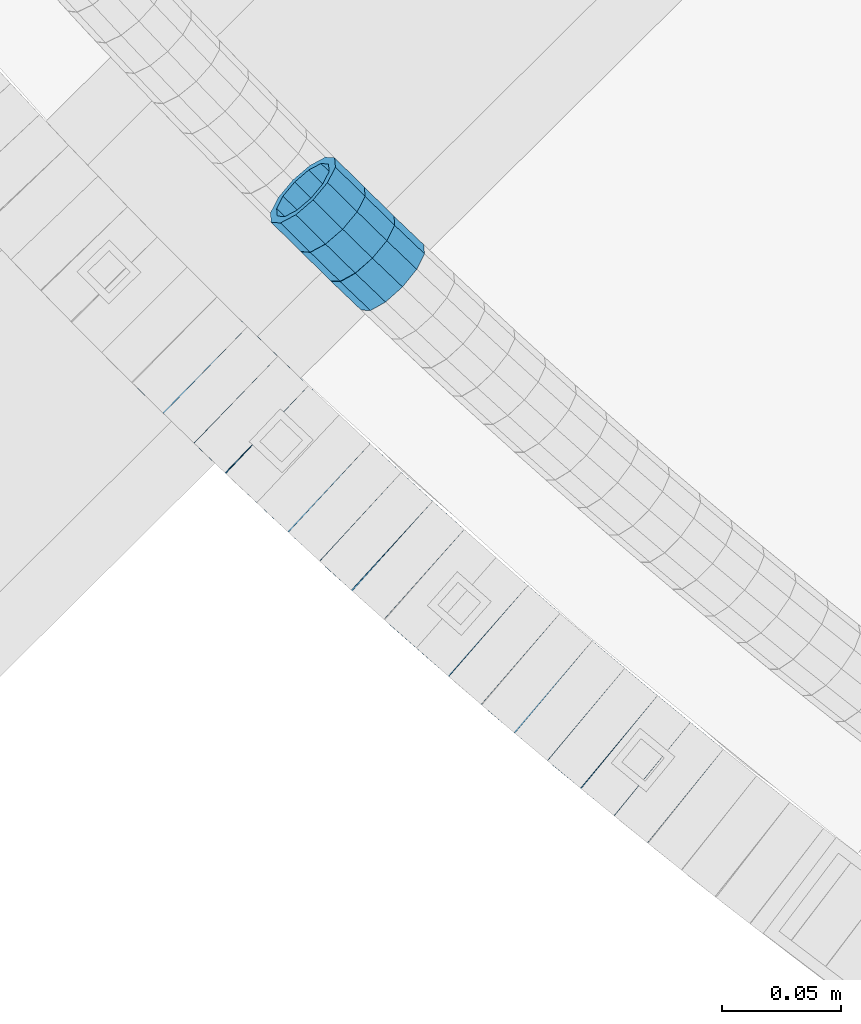
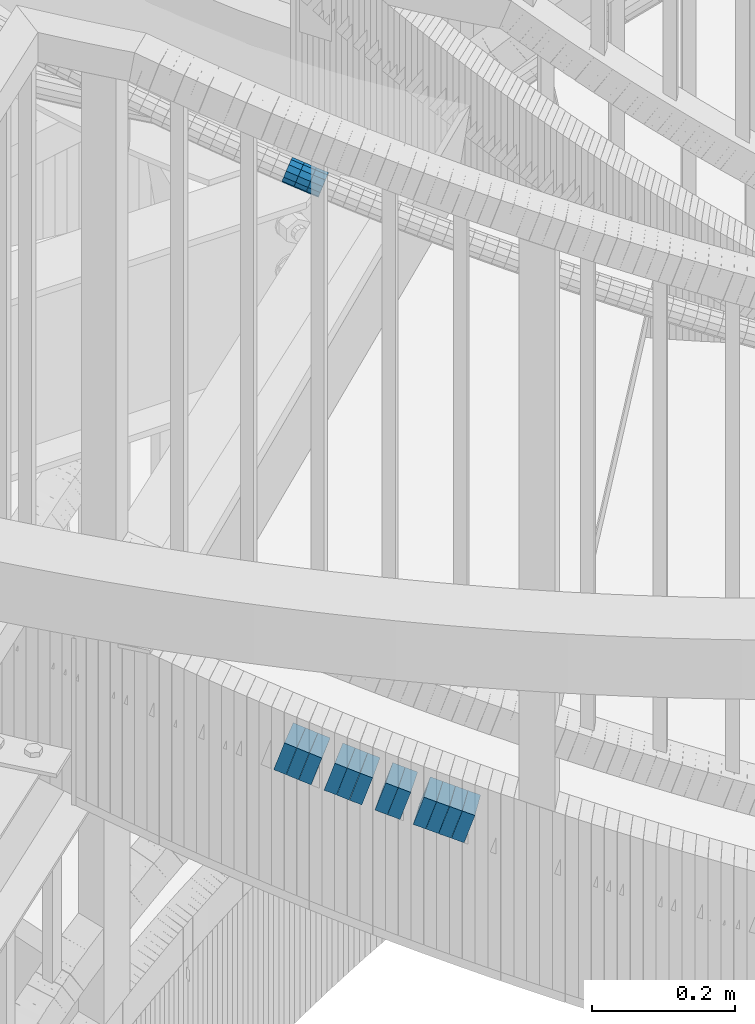
# One storey, part 662 of 975: 15 beams.
"""IFC2X3 building model written with IfcOpenShell, lengths in millimetres."""

from ifc_helpers import new_model, si_unit, frame, origin_with_axes, place, context, subcontext, project, spatial, faceted_brep, material, type_object, element, save


model = new_model("IFC2X3")

# Units and contexts
model_context = context("Model", 3, precision=1e-05, world=origin_with_axes())
body_context = subcontext(model_context, "Body", "Model", "MODEL_VIEW")
ifc_project = project(units=[si_unit("LENGTHUNIT", "METRE", prefix="MILLI"), si_unit("AREAUNIT", "SQUARE_METRE"), si_unit("VOLUMEUNIT", "CUBIC_METRE"), si_unit("MASSUNIT", "GRAM", prefix="KILO"), si_unit("TIMEUNIT", "SECOND"), si_unit("PLANEANGLEUNIT", "RADIAN"), si_unit("SOLIDANGLEUNIT", "STERADIAN"), si_unit("THERMODYNAMICTEMPERATUREUNIT", "DEGREE_CELSIUS"), si_unit("LUMINOUSINTENSITYUNIT", "LUMEN")], contexts=[model_context])

# Site, building, storey
site_placement = place(None, origin_with_axes())
site = spatial("IfcSite", under=ifc_project, at=site_placement, CompositionType="ELEMENT")
building_placement = place(site_placement, origin_with_axes())
building = spatial("IfcBuilding", under=site, at=building_placement, Name="Undefined", CompositionType="ELEMENT")
storey_placement = place(building_placement, origin_with_axes())
storey = spatial("IfcBuildingStorey", under=building, at=storey_placement, Name="Undefined", CompositionType="ELEMENT", Elevation=0.0)

# Beams
ifc_material = material()
beam_type_1 = type_object("IfcBeamType", PredefinedType="NOTDEFINED")
beam_1_placement = place(storey_placement, frame((32770.5328769577, 1424.90290854378, 4922.613522137), z_axis=(0.701381499778907, 0.712786077142287, 8.51287040859459e-11), x_axis=(0.676734364812168, -0.665906614815096, -0.314004744912829)))
element("IfcBeam", 1, at=beam_1_placement, inside=storey, type_object=beam_type_1, material=ifc_material, Name="WALL", context=body_context, shape_type="Brep", body=[
    faceted_brep([(-2.1246523829177e-07, -15.367000000002, 0.0), (-1.83998054126278e-07, -13.3082123799541, 7.68350000000009), (18.4672683416502, -13.3082123799759, 7.68350000002465), (18.4672683416611, -15.3670000000202, 3.09228198602796e-11), (-1.06232619145885e-07, -7.68349999999919, 13.3082123799559), (18.467268341632, -7.68350000001737, 13.3082123799704), (-3.63797880709171e-12, 3.63797880709171e-12, 15.3670000000002), (18.4672683416175, -1.09139364212751e-11, 15.3670000000075), (1.06225343188271e-07, 7.68350000000646, 13.3082123799559), (18.4672683416102, 7.68349999998827, 13.3082123799613), (1.8399441614747e-07, 13.308212379965, 7.68350000000009), (18.4672683416138, 13.3082123799468, 7.68350000000464), (2.12461600312963e-07, 15.3670000000093, 0.0), (18.4672683416138, 15.3669999999929, 5.45696821063757e-12), (1.8399441614747e-07, 13.308212379965, -7.68350000000009), (18.4672683416284, 13.308212379945, -7.68349999998827), (1.06225343188271e-07, 7.68350000000646, -13.3082123799559), (18.4672683416429, 7.68349999998827, -13.3082123799359), (-3.63797880709171e-12, 3.63797880709171e-12, -15.3670000000002), (18.4672683416611, -1.63709046319127e-11, -15.3669999999747), (-1.06232619145885e-07, -7.68349999999919, -13.3082123799559), (18.4672683416647, -7.68350000001919, -13.3082123799268), (-1.83998054126278e-07, -13.3082123799541, -7.68350000000009), (18.4672683416684, -13.3082123799759, -7.68349999997008), (-2.63386027654633e-07, -19.0500000000029, 0.0), (-2.28097633225843e-07, -16.4977839420972, -9.52499999999964), (18.4672683416793, -16.4977839421172, -9.52499999996508), (18.467268341672, -19.0500000000247, 3.27418092638254e-11), (-1.31691194837913e-07, -9.52500000000146, -16.4977839420935), (18.4672683416757, -9.52500000002328, -16.497783942059), (-3.63797880709171e-12, 3.63797880709171e-12, -19.0500000000002), (18.4672683416611, -1.45519152283669e-11, -19.0499999999738), (1.31687556859106e-07, 9.52500000000509, -16.4977839420935), (18.4672683416502, 9.5249999999869, -16.4977839420735), (2.28097633225843e-07, 16.4977839421044, -9.52499999999964), (18.4672683416247, 16.4977839420862, -9.52499999998872), (2.63382389675826e-07, 19.0500000000138, 0.0), (18.4672683416029, 19.0499999999956, 1.81898940354586e-12), (2.28097633225843e-07, 16.4977839421044, 9.52499999999964), (18.4672683416065, 16.4977839420862, 9.52500000000146), (1.31687556859106e-07, 9.52500000000509, 16.4977839420935), (18.4672683415993, 9.52499999999236, 16.4977839420917), (-3.63797880709171e-12, 3.63797880709171e-12, 19.0500000000002), (18.4672683416138, -1.45519152283669e-11, 19.0500000000084), (-1.31691194837913e-07, -9.52500000000146, 16.4977839420935), (18.4672683416356, -9.52500000001783, 16.4977839421117), (-2.28097633225843e-07, -16.4977839420972, 9.52499999999964), (18.4672683416538, -16.4977839421135, 9.5250000000251)], [[[0, 1, 2, 3]], [[1, 4, 5, 2]], [[4, 6, 7, 5]], [[6, 8, 9, 7]], [[8, 10, 11, 9]], [[10, 12, 13, 11]], [[12, 14, 15, 13]], [[14, 16, 17, 15]], [[16, 18, 19, 17]], [[18, 20, 21, 19]], [[20, 22, 23, 21]], [[22, 0, 3, 23]], [[24, 25, 26, 27]], [[25, 28, 29, 26]], [[28, 30, 31, 29]], [[30, 32, 33, 31]], [[32, 34, 35, 33]], [[34, 36, 37, 35]], [[36, 38, 39, 37]], [[38, 40, 41, 39]], [[40, 42, 43, 41]], [[42, 44, 45, 43]], [[44, 46, 47, 45]], [[46, 24, 27, 47]], [[29, 31, 33, 35, 37, 39, 41, 43, 45, 47, 27, 26], [5, 7, 9, 11, 13, 15, 17, 19, 21, 23, 3, 2]], [[46, 44, 42, 40, 38, 36, 34, 32, 30, 28, 25, 24], [22, 20, 18, 16, 14, 12, 10, 8, 6, 4, 1, 0]]]),
])
beam_2_placement = place(storey_placement, frame((32795.5342645722, 1400.26836988703, 4911.08251313694), z_axis=(0.689797510046803, 0.724002344701473, -7.79255060479045e-11), x_axis=(0.688561837943278, -0.656031357946014, -0.309039564974591)))
element("IfcBeam", 2, at=beam_2_placement, inside=storey, type_object=beam_type_1, material=ifc_material, Name="WALL", context=body_context, shape_type="Brep", body=[
    faceted_brep([(-2.1246523829177e-07, -15.367000000002, 0.0), (-1.83998054126278e-07, -13.3082123799541, 7.68350000000009), (18.4442402933746, -13.3082123799431, 7.68349999998463), (18.4442402933928, -15.3669999999893, -3.63797880709171e-12), (-1.06232619145885e-07, -7.68349999999919, 13.3082123799559), (18.4442402933564, -7.68349999998281, 13.308212379925), (-3.63797880709171e-12, 3.63797880709171e-12, 15.3670000000002), (18.4442402933455, 1.81898940354586e-11, 15.3669999999584), (1.06225343188271e-07, 7.68350000000646, 13.3082123799559), (18.4442402933419, 7.68350000001737, 13.3082123799104), (1.8399441614747e-07, 13.308212379965, 7.68350000000009), (18.4442402933528, 13.3082123799722, 7.68349999996281), (2.12461600312963e-07, 15.3670000000093, 0.0), (18.4442402933637, 15.3670000000129, -2.5465851649642e-11), (1.8399441614747e-07, 13.308212379965, -7.68350000000009), (18.4442402933855, 13.308212379965, -7.6835000000101), (1.06225343188271e-07, 7.68350000000646, -13.3082123799559), (18.4442402934037, 7.68350000000646, -13.3082123799541), (-3.63797880709171e-12, 3.63797880709171e-12, -15.3670000000002), (18.444240293411, 5.45696821063757e-12, -15.3669999999911), (-1.06232619145885e-07, -7.68349999999919, -13.3082123799559), (18.4442402934146, -7.68349999999373, -13.3082123799431), (-1.83998054126278e-07, -13.3082123799541, -7.68350000000009), (18.4442402934037, -13.3082123799468, -7.68349999999191), (-2.63386027654633e-07, -19.0500000000029, 0.0), (-2.28097633225843e-07, -16.4977839420972, -9.52499999999964), (18.444240293411, -16.4977839420862, -9.5249999999869), (18.4442402933964, -19.0499999999902, 0.0), (-1.31691194837913e-07, -9.52500000000146, -16.4977839420935), (18.4442402934219, -9.524999999996, -16.4977839420717), (-3.63797880709171e-12, 3.63797880709171e-12, -19.0500000000002), (18.4442402934183, 3.63797880709171e-12, -19.0499999999847), (1.31687556859106e-07, 9.52500000000509, -16.4977839420935), (18.4442402934073, 9.52500000000509, -16.4977839420899), (2.28097633225843e-07, 16.4977839421044, -9.52499999999964), (18.4442402933855, 16.4977839421008, -9.52500000001601), (2.63382389675826e-07, 19.0500000000138, 0.0), (18.4442402933637, 19.0500000000138, -2.91038304567337e-11), (2.28097633225843e-07, 16.4977839421044, 9.52499999999964), (18.4442402933419, 16.4977839421117, 9.52499999995052), (1.31687556859106e-07, 9.52500000000509, 16.4977839420935), (18.4442402933346, 9.52500000001965, 16.4977839420426), (-3.63797880709171e-12, 3.63797880709171e-12, 19.0500000000002), (18.4442402933346, 2.00088834390044e-11, 19.0499999999483), (-1.31691194837913e-07, -9.52500000000146, 16.4977839420935), (18.4442402933528, -9.52499999998145, 16.4977839420571), (-2.28097633225843e-07, -16.4977839420972, 9.52499999999964), (18.4442402933746, -16.497783942079, 9.52499999998327)], [[[0, 1, 2, 3]], [[1, 4, 5, 2]], [[4, 6, 7, 5]], [[6, 8, 9, 7]], [[8, 10, 11, 9]], [[10, 12, 13, 11]], [[12, 14, 15, 13]], [[14, 16, 17, 15]], [[16, 18, 19, 17]], [[18, 20, 21, 19]], [[20, 22, 23, 21]], [[22, 0, 3, 23]], [[24, 25, 26, 27]], [[25, 28, 29, 26]], [[28, 30, 31, 29]], [[30, 32, 33, 31]], [[32, 34, 35, 33]], [[34, 36, 37, 35]], [[36, 38, 39, 37]], [[38, 40, 41, 39]], [[40, 42, 43, 41]], [[42, 44, 45, 43]], [[44, 46, 47, 45]], [[46, 24, 27, 47]], [[29, 31, 33, 35, 37, 39, 41, 43, 45, 47, 27, 26], [5, 7, 9, 11, 13, 15, 17, 19, 21, 23, 3, 2]], [[46, 44, 42, 40, 38, 36, 34, 32, 30, 28, 25, 24], [22, 20, 18, 16, 14, 12, 10, 8, 6, 4, 1, 0]]]),
])
beam_3_placement = place(storey_placement, frame((32783.0672260718, 1412.53527391315, 4916.78990991588), z_axis=(0.698466923246537, 0.715642338833105, -9.56160874920895e-11), x_axis=(0.680333189806667, -0.664005193811269, -0.310231934911841)))
element("IfcBeam", 3, at=beam_3_placement, inside=storey, type_object=beam_type_1, material=ifc_material, Name="WALL", context=body_context, shape_type="Brep", body=[
    faceted_brep([(-2.1246523829177e-07, -15.367000000002, 0.0), (-1.83998054126278e-07, -13.3082123799541, 7.68350000000009), (18.3709009033701, -13.308212379965, 7.68350000000646), (18.370900903381, -15.3670000000202, 1.09139364212751e-11), (-1.06232619145885e-07, -7.68349999999919, 13.3082123799559), (18.3709009033519, -7.68349999999919, 13.3082123799559), (-3.63797880709171e-12, 3.63797880709171e-12, 15.3670000000002), (18.3709009033337, 1.09139364212751e-11, 15.3669999999893), (1.06225343188271e-07, 7.68350000000646, 13.3082123799559), (18.3709009033155, 7.68350000001737, 13.3082123799395), (1.8399441614747e-07, 13.308212379965, 7.68350000000009), (18.3709009033191, 13.3082123799759, 7.68349999998463), (2.12461600312963e-07, 15.3670000000093, 0.0), (18.3709009033191, 15.3670000000166, -1.45519152283669e-11), (1.8399441614747e-07, 13.308212379965, -7.68350000000009), (18.3709009033337, 13.3082123799613, -7.68350000000828), (1.06225343188271e-07, 7.68350000000646, -13.3082123799559), (18.3709009033482, 7.68349999999555, -13.3082123799577), (-3.63797880709171e-12, 3.63797880709171e-12, -15.3670000000002), (18.3709009033737, -1.45519152283669e-11, -15.3669999999929), (-1.06232619145885e-07, -7.68349999999919, -13.3082123799559), (18.3709009033846, -7.68350000002101, -13.3082123799431), (-1.83998054126278e-07, -13.3082123799541, -7.68350000000009), (18.3709009033846, -13.3082123799759, -7.68349999998827), (-2.63386027654633e-07, -19.0500000000029, 0.0), (-2.28097633225843e-07, -16.4977839420972, -9.52499999999964), (18.3709009033992, -16.4977839421226, -9.52499999998145), (18.3709009033882, -19.0500000000229, 1.45519152283669e-11), (-1.31691194837913e-07, -9.52500000000146, -16.4977839420935), (18.3709009033919, -9.52500000002692, -16.4977839420771), (-3.63797880709171e-12, 3.63797880709171e-12, -19.0500000000002), (18.3709009033701, -1.45519152283669e-11, -19.0499999999938), (1.31687556859106e-07, 9.52500000000509, -16.4977839420935), (18.3709009033519, 9.524999999996, -16.4977839420935), (2.28097633225843e-07, 16.4977839421044, -9.52499999999964), (18.37090090333, 16.4977839421044, -9.52500000001055), (2.63382389675826e-07, 19.0500000000138, 0.0), (18.3709009033118, 19.0500000000211, -1.81898940354586e-11), (2.28097633225843e-07, 16.4977839421044, 9.52499999999964), (18.3709009033082, 16.497783942119, 9.52499999997963), (1.31687556859106e-07, 9.52500000000509, 16.4977839420935), (18.3709009033118, 9.52500000002328, 16.4977839420753), (-3.63797880709171e-12, 3.63797880709171e-12, 19.0500000000002), (18.37090090333, 1.45519152283669e-11, 19.0499999999902), (-1.31691194837913e-07, -9.52500000000146, 16.4977839420935), (18.3709009033555, -9.52499999999782, 16.4977839420935), (-2.28097633225843e-07, -16.4977839420972, 9.52499999999964), (18.370900903381, -16.4977839421081, 9.52500000000873)], [[[0, 1, 2, 3]], [[1, 4, 5, 2]], [[4, 6, 7, 5]], [[6, 8, 9, 7]], [[8, 10, 11, 9]], [[10, 12, 13, 11]], [[12, 14, 15, 13]], [[14, 16, 17, 15]], [[16, 18, 19, 17]], [[18, 20, 21, 19]], [[20, 22, 23, 21]], [[22, 0, 3, 23]], [[24, 25, 26, 27]], [[25, 28, 29, 26]], [[28, 30, 31, 29]], [[30, 32, 33, 31]], [[32, 34, 35, 33]], [[34, 36, 37, 35]], [[36, 38, 39, 37]], [[38, 40, 41, 39]], [[40, 42, 43, 41]], [[42, 44, 45, 43]], [[44, 46, 47, 45]], [[46, 24, 27, 47]], [[29, 31, 33, 35, 37, 39, 41, 43, 45, 47, 27, 26], [5, 7, 9, 11, 13, 15, 17, 19, 21, 23, 3, 2]], [[46, 44, 42, 40, 38, 36, 34, 32, 30, 28, 25, 24], [22, 20, 18, 16, 14, 12, 10, 8, 6, 4, 1, 0]]]),
])
beam_type_2 = type_object("IfcBeamType", Name="HSS2X2X.188_TUBES", PredefinedType="NOTDEFINED")
beam_4_placement = place(storey_placement, frame((32724.0344169392, 1354.4145673792, 3996.30731278571), z_axis=(0.695795215779443, 0.718240222835256, 1.40034899231978e-11), x_axis=(0.684100829257296, -0.662722678249241, -0.304638650114579)))
element("IfcBeam", 4, at=beam_4_placement, inside=storey, type_object=beam_type_2, material=ifc_material, Name="WALL", ObjectType="HSS2X2X.188_TUBES", context=body_context, shape_type="Brep", body=[
    faceted_brep([(0.0, 20.6374999999753, -20.6375000000298), (0.0, -20.6375000000153, -20.6375000000153), (18.7112265765609, -20.6375000000062, -20.6374999999862), (18.7112265765645, 20.6374999999898, -20.6374999999789), (0.0, -20.6374999999825, 20.6375000000335), (18.7112265765209, -20.6374999999916, 20.6374999999607), (0.0, 20.6375000000116, 20.6375000000189), (18.7112265765245, 20.6375000000025, 20.6374999999716), (0.0, 25.3999999999724, -25.4000000000342), (0.0, 25.400000000016, 25.4000000000196), (18.7112265765172, 25.4000000000051, 25.3999999999614), (18.7112265765718, 25.3999999999887, -25.3999999999724), (0.0, -25.399999999976, 25.4000000000378), (18.7112265765136, -25.3999999999905, 25.3999999999542), (0.0, -25.400000000016, -25.4000000000196), (18.7112265765682, -25.4000000000069, -25.3999999999796)], [[[0, 1, 2, 3]], [[1, 4, 5, 2]], [[4, 6, 7, 5]], [[6, 0, 3, 7]], [[8, 9, 10, 11]], [[9, 12, 13, 10]], [[12, 14, 15, 13]], [[14, 8, 11, 15]], [[13, 15, 11, 10], [5, 7, 3, 2]], [[14, 12, 9, 8], [6, 4, 1, 0]]]),
])
beam_5_placement = place(storey_placement, frame((32736.9049610275, 1341.90475522226, 3990.59829667296), z_axis=(0.692997020219925, 0.720940448280095, 1.13263922685292e-11), x_axis=(0.686928616140534, -0.660303476135105, -0.303526598062094)))
element("IfcBeam", 5, at=beam_5_placement, inside=storey, type_object=beam_type_2, material=ifc_material, Name="WALL", ObjectType="HSS2X2X.188_TUBES", context=body_context, shape_type="Brep", body=[
    faceted_brep([(0.0, 20.6374999999753, -20.6375000000298), (0.0, -20.6375000000153, -20.6375000000153), (18.7771137292038, -20.637500000008, -20.6374999999862), (18.777113729182, 20.6375000000062, -20.6375000000189), (0.0, -20.6374999999825, 20.6375000000335), (18.7771137291729, -20.6374999999916, 20.6374999999753), (0.0, 20.6375000000116, 20.6375000000189), (18.7771137291529, 20.6375000000207, 20.6374999999389), (0.0, 25.3999999999724, -25.4000000000342), (0.0, 25.400000000016, 25.4000000000196), (18.7771137291475, 25.4000000000251, 25.3999999999287), (18.7771137291857, 25.4000000000051, -25.4000000000196), (0.0, -25.399999999976, 25.4000000000378), (18.7771137291711, -25.3999999999905, 25.3999999999724), (0.0, -25.400000000016, -25.4000000000196), (18.7771137292129, -25.4000000000124, -25.3999999999724)], [[[0, 1, 2, 3]], [[1, 4, 5, 2]], [[4, 6, 7, 5]], [[6, 0, 3, 7]], [[8, 9, 10, 11]], [[9, 12, 13, 10]], [[12, 14, 15, 13]], [[14, 8, 11, 15]], [[13, 15, 11, 10], [5, 7, 3, 2]], [[14, 12, 9, 8], [6, 4, 1, 0]]]),
])
beam_6_placement = place(storey_placement, frame((32749.8715593652, 1329.35444516325, 3984.91567673949), z_axis=(0.687119514852114, 0.726544404912319, 1.51526364788878e-11), x_axis=(0.691771053474231, -0.65423308944851, -0.305666279209551)))
element("IfcBeam", 6, at=beam_6_placement, inside=storey, type_object=beam_type_2, material=ifc_material, Name="WALL", ObjectType="HSS2X2X.188_TUBES", context=body_context, shape_type="Brep", body=[
    faceted_brep([(0.0, 20.6374999999753, -20.6375000000298), (0.0, -20.6375000000153, -20.6375000000153), (18.6531498680506, -20.6374999999862, -20.6375000000007), (18.6531498680579, 20.637500000008, -20.6374999999935), (0.0, -20.6374999999825, 20.6375000000335), (18.6531498680379, -20.6374999999971, 20.6374999999789), (0.0, 20.6375000000116, 20.6375000000189), (18.6531498680451, 20.6374999999989, 20.6374999999898), (0.0, 25.3999999999724, -25.4000000000342), (0.0, 25.400000000016, 25.4000000000196), (18.653149868047, 25.399999999996, 25.3999999999869), (18.6531498680633, 25.4000000000087, -25.3999999999905), (0.0, -25.399999999976, 25.4000000000378), (18.6531498680361, -25.3999999999978, 25.3999999999796), (0.0, -25.400000000016, -25.4000000000196), (18.6531498680488, -25.3999999999851, -25.4000000000015)], [[[0, 1, 2, 3]], [[1, 4, 5, 2]], [[4, 6, 7, 5]], [[6, 0, 3, 7]], [[8, 9, 10, 11]], [[9, 12, 13, 10]], [[12, 14, 15, 13]], [[14, 8, 11, 15]], [[13, 15, 11, 10], [5, 7, 3, 2]], [[14, 12, 9, 8], [6, 4, 1, 0]]]),
])
beam_7_placement = place(storey_placement, frame((32776.0502930621, 1304.66244969557, 3973.40583006654), z_axis=(0.678512969955015, 0.734588421909048, -9.16134013095869e-12), x_axis=(0.699714846980974, -0.646301499982326, -0.304456078991678)))
element("IfcBeam", 7, at=beam_7_placement, inside=storey, type_object=beam_type_2, material=ifc_material, Name="WALL", ObjectType="HSS2X2X.188_TUBES", context=body_context, shape_type="Brep", body=[
    faceted_brep([(0.0, 20.6374999999753, -20.6375000000298), (0.0, -20.6375000000153, -20.6375000000153), (18.724849799155, -20.6375000000171, -20.6374999999425), (18.7248497991204, 20.6374999999989, -20.6375000000007), (0.0, -20.6374999999825, 20.6375000000335), (18.7248497991168, -20.6374999999953, 20.6375000000007), (0.0, 20.6375000000116, 20.6375000000189), (18.724849799084, 20.6375000000226, 20.6374999999498), (0.0, 25.3999999999724, -25.4000000000342), (0.0, 25.400000000016, 25.4000000000196), (18.7248497990731, 25.4000000000269, 25.399999999936), (18.7248497991204, 25.3999999999978, -25.3999999999978), (0.0, -25.399999999976, 25.4000000000378), (18.7248497991186, -25.3999999999942, 25.4000000000051), (0.0, -25.400000000016, -25.4000000000196), (18.7248497991604, -25.4000000000233, -25.3999999999323)], [[[0, 1, 2, 3]], [[1, 4, 5, 2]], [[4, 6, 7, 5]], [[6, 0, 3, 7]], [[8, 9, 10, 11]], [[9, 12, 13, 10]], [[12, 14, 15, 13]], [[14, 8, 11, 15]], [[13, 15, 11, 10], [5, 7, 3, 2]], [[14, 12, 9, 8], [6, 4, 1, 0]]]),
])
beam_8_placement = place(storey_placement, frame((32789.2225427684, 1292.4562229374, 3967.69662764212), z_axis=(0.675724628076021, 0.737154140605289, 3.47004515788284e-10), x_axis=(0.702425832939866, -0.643890345944859, -0.303320245974027)))
element("IfcBeam", 8, at=beam_8_placement, inside=storey, type_object=beam_type_2, material=ifc_material, Name="WALL", ObjectType="HSS2X2X.188_TUBES", context=body_context, shape_type="Brep", body=[
    faceted_brep([(0.0, 20.6374999999753, -20.6375000000298), (0.0, -20.6375000000153, -20.6375000000153), (18.7853666454903, -20.6375000000535, -20.6375000000326), (18.785366645363, 20.6374999999862, -20.6375000000044), (0.0, -20.6374999999825, 20.6375000000335), (18.785366645352, -20.6375000000007, 20.6374999999989), (0.0, 20.6375000000116, 20.6375000000189), (18.7853666453102, 20.6375000000025, 20.6374999999753), (0.0, 25.3999999999724, -25.4000000000342), (0.0, 25.400000000016, 25.4000000000196), (18.7853666452065, 25.4000000000451, 25.4000000000351), (18.7853666453739, 25.3999999999833, -25.400000000006), (0.0, -25.399999999976, 25.4000000000378), (18.7853666497213, -25.399999993424, 25.3999999995158), (0.0, -25.400000000016, -25.4000000000196), (18.7853666455194, -25.4000000000633, -25.4000000000406)], [[[0, 1, 2, 3]], [[1, 4, 5, 2]], [[4, 6, 7, 5]], [[6, 0, 3, 7]], [[8, 9, 10, 11]], [[9, 12, 13, 10]], [[12, 14, 15, 13]], [[14, 8, 11, 15]], [[13, 15, 11, 10], [5, 7, 3, 2]], [[14, 12, 9, 8], [6, 4, 1, 0]]]),
])
beam_9_placement = place(storey_placement, frame((32802.5694943261, 1280.09772085819, 3962.00413998626), z_axis=(0.666794859061833, 0.745241313890145, -3.81132849724964e-11), x_axis=(0.709911595043128, -0.635184058038575, -0.304247826018478)))
element("IfcBeam", 9, at=beam_9_placement, inside=storey, type_object=beam_type_2, material=ifc_material, Name="WALL", ObjectType="HSS2X2X.188_TUBES", context=body_context, shape_type="Brep", body=[
    faceted_brep([(0.0, 20.6374999999753, -20.6375000000298), (0.0, -20.6375000000153, -20.6375000000153), (18.7347271129966, -20.6375000000116, -20.6375000000262), (18.7347271130257, 20.6374999999989, -20.6374999999935), (0.0, -20.6374999999825, 20.6375000000335), (18.7347271129947, -20.6375000000116, 20.6374999999607), (0.0, 20.6375000000116, 20.6375000000189), (18.7347271130147, 20.6375000000007, 20.6374999999898), (0.0, 25.3999999999724, -25.4000000000342), (0.0, 25.400000000016, 25.4000000000196), (18.7347271130166, 25.4000000000015, 25.3999999999905), (18.7347271130257, 25.3999999999996, -25.3999999999869), (0.0, -25.399999999976, 25.4000000000378), (18.7347271129875, -25.4000000000106, 25.3999999999505), (0.0, -25.400000000016, -25.4000000000196), (18.7347271130002, -25.4000000000124, -25.4000000000233)], [[[0, 1, 2, 3]], [[1, 4, 5, 2]], [[4, 6, 7, 5]], [[6, 0, 3, 7]], [[8, 9, 10, 11]], [[9, 12, 13, 10]], [[12, 14, 15, 13]], [[14, 8, 11, 15]], [[13, 15, 11, 10], [5, 7, 3, 2]], [[14, 12, 9, 8], [6, 4, 1, 0]]]),
])
beam_10_placement = place(storey_placement, frame((32829.4211527866, 1256.03841105095, 3950.51139134731), z_axis=(0.657708283716797, 0.7532727351566, 1.01358637039084e-10), x_axis=(0.717347220641355, -0.62634048368686, -0.305140235847443)))
element("IfcBeam", 10, at=beam_10_placement, inside=storey, type_object=beam_type_2, material=ifc_material, Name="WALL", ObjectType="HSS2X2X.188_TUBES", context=body_context, shape_type="Brep", body=[
    faceted_brep([(0.0, 20.6374999999753, -20.6375000000298), (0.0, -20.6375000000153, -20.6375000000153), (18.677794302308, -20.6374999999989, -20.6374999999862), (18.6777943022862, 20.6375000000098, -20.6375000000153), (0.0, -20.6374999999825, 20.6375000000335), (18.6777943022862, -20.6375000000044, 20.6374999999862), (0.0, 20.6375000000116, 20.6375000000189), (18.6777943022644, 20.6375000000044, 20.6374999999571), (0.0, 25.3999999999724, -25.4000000000342), (0.0, 25.400000000016, 25.4000000000196), (18.6777943022607, 25.4000000000033, 25.3999999999505), (18.6777943022898, 25.4000000000124, -25.400000000016), (0.0, -25.399999999976, 25.4000000000378), (18.6777943022862, -25.4000000000069, 25.3999999999905), (0.0, -25.400000000016, -25.4000000000196), (18.6777943023117, -25.3999999999978, -25.3999999999796)], [[[0, 1, 2, 3]], [[1, 4, 5, 2]], [[4, 6, 7, 5]], [[6, 0, 3, 7]], [[8, 9, 10, 11]], [[9, 12, 13, 10]], [[12, 14, 15, 13]], [[14, 8, 11, 15]], [[13, 15, 11, 10], [5, 7, 3, 2]], [[14, 12, 9, 8], [6, 4, 1, 0]]]),
])
beam_11_placement = place(storey_placement, frame((32842.895425813, 1244.23605323274, 3944.80189390617), z_axis=(0.654930538567539, 0.75568908266008, -2.07875018531922e-10), x_axis=(0.719930889850579, -0.623940104870516, -0.303970819936918)))
element("IfcBeam", 11, at=beam_11_placement, inside=storey, type_object=beam_type_2, material=ifc_material, Name="WALL", ObjectType="HSS2X2X.188_TUBES", context=body_context, shape_type="Brep", body=[
    faceted_brep([(0.0, 20.6374999999753, -20.6375000000298), (0.0, -20.6375000000153, -20.6375000000153), (18.7547327359644, -20.6374999999844, -20.6375000000553), (18.7547327359898, 20.6375000000171, -20.6375000000335), (0.0, -20.6374999999825, 20.6375000000335), (18.7547327360044, -20.6374999999953, 20.6374999999898), (0.0, 20.6375000000116, 20.6375000000189), (18.7547327360262, 20.6375000000062, 20.6375000000116), (0.0, 25.3999999999724, -25.4000000000342), (0.0, 25.400000000016, 25.4000000000196), (18.7547327360371, 25.4000000000033, 25.4000000000124), (18.7547327359898, 25.4000000000178, -25.4000000000342), (0.0, -25.399999999976, 25.4000000000378), (18.7547327360044, -25.399999999996, 25.3999999999869), (0.0, -25.400000000016, -25.4000000000196), (18.7547327359498, -25.3999999999814, -25.4000000000597)], [[[0, 1, 2, 3]], [[1, 4, 5, 2]], [[4, 6, 7, 5]], [[6, 0, 3, 7]], [[8, 9, 10, 11]], [[9, 12, 13, 10]], [[12, 14, 15, 13]], [[14, 8, 11, 15]], [[13, 15, 11, 10], [5, 7, 3, 2]], [[14, 12, 9, 8], [6, 4, 1, 0]]]),
])
beam_12_placement = place(storey_placement, frame((32870.2279288728, 1220.57776558199, 3933.29909806896), z_axis=(0.642929821248529, 0.765925090951677, -7.05604179529472e-11), x_axis=(0.729766851144476, -0.612578014121283, -0.303625624060127)))
element("IfcBeam", 12, at=beam_12_placement, inside=storey, type_object=beam_type_2, material=ifc_material, Name="WALL", ObjectType="HSS2X2X.188_TUBES", context=body_context, shape_type="Brep", body=[
    faceted_brep([(0.0, 20.6374999999753, -20.6375000000298), (0.0, -20.6375000000153, -20.6375000000153), (18.767258723612, -20.6375000000025, -20.6374999999862), (18.7672587236229, 20.6374999999953, -20.637499999968), (0.0, -20.6374999999825, 20.6375000000335), (18.767258723612, -20.6375000000135, 20.6375000000153), (0.0, 20.6375000000116, 20.6375000000189), (18.7672587236266, 20.6374999999844, 20.6375000000371), (0.0, 25.3999999999724, -25.4000000000342), (0.0, 25.400000000016, 25.4000000000196), (18.7672587236302, 25.3999999999814, 25.4000000000342), (18.7672587236229, 25.399999999996, -25.3999999999687), (0.0, -25.399999999976, 25.4000000000378), (18.7672587236157, -25.4000000000142, 25.400000000016), (0.0, -25.400000000016, -25.4000000000196), (18.767258723612, -25.4000000000015, -25.3999999999905)], [[[0, 1, 2, 3]], [[1, 4, 5, 2]], [[4, 6, 7, 5]], [[6, 0, 3, 7]], [[8, 9, 10, 11]], [[9, 12, 13, 10]], [[12, 14, 15, 13]], [[14, 8, 11, 15]], [[13, 15, 11, 10], [5, 7, 3, 2]], [[14, 12, 9, 8], [6, 4, 1, 0]]]),
])
beam_13_placement = place(storey_placement, frame((32884.0029344645, 1208.97911920347, 3927.58958585575), z_axis=(0.640184399851998, 0.768221279441111, -7.74534782976843e-11), x_axis=(0.732242336120608, -0.610201947100525, -0.302447921049828)))
element("IfcBeam", 13, at=beam_13_placement, inside=storey, type_object=beam_type_2, material=ifc_material, Name="WALL", ObjectType="HSS2X2X.188_TUBES", context=body_context, shape_type="Brep", body=[
    faceted_brep([(0.0, 20.6374999999753, -20.6375000000298), (0.0, -20.6375000000153, -20.6375000000153), (18.8480768248774, -20.6374999999716, -20.6375000000735), (18.8480768249356, 20.6375000000153, -20.6375000000226), (0.0, -20.6374999999825, 20.6375000000335), (18.8480768249283, -20.6374999999935, 20.6374999999716), (0.0, 20.6375000000116, 20.6375000000189), (18.8480768249865, 20.6374999999935, 20.6375000000262), (0.0, 25.3999999999724, -25.4000000000342), (0.0, 25.400000000016, 25.4000000000196), (18.848076825001, 25.3999999999887, 25.4000000000378), (18.8480768249392, 25.4000000000142, -25.4000000000233), (0.0, -25.399999999976, 25.4000000000378), (18.8480768249283, -25.399999999996, 25.3999999999833), (0.0, -25.400000000016, -25.4000000000196), (18.8480768248664, -25.3999999999687, -25.4000000000779)], [[[0, 1, 2, 3]], [[1, 4, 5, 2]], [[4, 6, 7, 5]], [[6, 0, 3, 7]], [[8, 9, 10, 11]], [[9, 12, 13, 10]], [[12, 14, 15, 13]], [[14, 8, 11, 15]], [[13, 15, 11, 10], [5, 7, 3, 2]], [[14, 12, 9, 8], [6, 4, 1, 0]]]),
])
beam_14_placement = place(storey_placement, frame((32897.7959590226, 1197.39808232553, 3921.94502291381), z_axis=(0.633543049896048, 0.773707440786512, -1.7827460396802e-11), x_axis=(0.73578289405886, -0.602488892048184, -0.309242086024721)))
element("IfcBeam", 14, at=beam_14_placement, inside=storey, type_object=beam_type_2, material=ifc_material, Name="WALL", ObjectType="HSS2X2X.188_TUBES", context=body_context, shape_type="Brep", body=[
    faceted_brep([(0.0, 20.6374999999753, -20.6375000000298), (0.0, -20.6375000000153, -20.6375000000153), (18.7555325170906, -20.6374999999916, -20.6374999999971), (18.7555325171452, 20.637499999988, -20.6374999999571), (0.0, -20.6374999999825, 20.6375000000335), (18.7555325170615, -20.6374999999844, 20.6374999999716), (0.0, 20.6375000000116, 20.6375000000189), (18.7555325171015, 20.6374999999953, 20.637500000008), (0.0, 25.3999999999724, -25.4000000000342), (0.0, 25.400000000016, 25.4000000000196), (18.7555325171015, 25.399999999996, 25.4000000000051), (18.7555325171488, 25.3999999999851, -25.3999999999505), (0.0, -25.399999999976, 25.4000000000378), (18.755532517047, -25.3999999999814, 25.3999999999578), (0.0, -25.400000000016, -25.4000000000196), (18.7555325170979, -25.3999999999924, -25.3999999999978)], [[[0, 1, 2, 3]], [[1, 4, 5, 2]], [[4, 6, 7, 5]], [[6, 0, 3, 7]], [[8, 9, 10, 11]], [[9, 12, 13, 10]], [[12, 14, 15, 13]], [[14, 8, 11, 15]], [[13, 15, 11, 10], [5, 7, 3, 2]], [[14, 12, 9, 8], [6, 4, 1, 0]]]),
])
beam_15_placement = place(storey_placement, frame((32911.7668291422, 1185.92316792941, 3916.09576019637), z_axis=(0.630802760458508, 0.775943217895437, -1.34193669509841e-10), x_axis=(0.739414005013083, -0.601106350010624, -0.303212937005361)))
element("IfcBeam", 15, at=beam_15_placement, inside=storey, type_object=beam_type_2, material=ifc_material, Name="WALL", ObjectType="HSS2X2X.188_TUBES", context=body_context, shape_type="Brep", body=[
    faceted_brep([(0.0, 20.6374999999753, -20.6375000000298), (0.0, -20.6375000000153, -20.6375000000153), (18.8047866246379, -20.6374999999916, -20.6375000000298), (18.8047866247143, 20.6374999999844, -20.6374999999643), (0.0, -20.6374999999825, 20.6375000000335), (18.8047866247107, -20.6375000000189, 20.6375000000407), (0.0, 20.6375000000116, 20.6375000000189), (18.8047866247907, 20.6374999999589, 20.6375000001026), (0.0, 25.3999999999724, -25.4000000000342), (0.0, 25.400000000016, 25.4000000000196), (18.8047866248016, 25.3999999999542, 25.4000000001142), (18.8047866247143, 25.3999999999851, -25.3999999999651), (0.0, -25.399999999976, 25.4000000000378), (18.8047866247107, -25.4000000000196, 25.4000000000415), (0.0, -25.400000000016, -25.4000000000196), (18.8047866246197, -25.3999999999887, -25.4000000000378)], [[[0, 1, 2, 3]], [[1, 4, 5, 2]], [[4, 6, 7, 5]], [[6, 0, 3, 7]], [[8, 9, 10, 11]], [[9, 12, 13, 10]], [[12, 14, 15, 13]], [[14, 8, 11, 15]], [[13, 15, 11, 10], [5, 7, 3, 2]], [[14, 12, 9, 8], [6, 4, 1, 0]]]),
])

save(model, "model.ifc")
